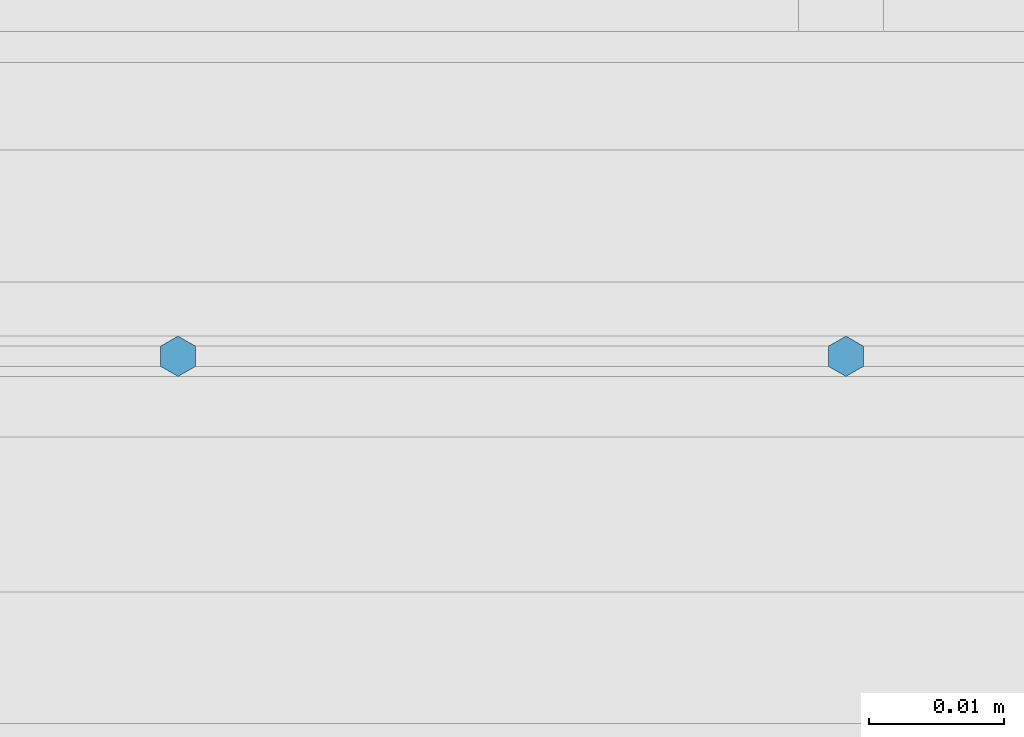
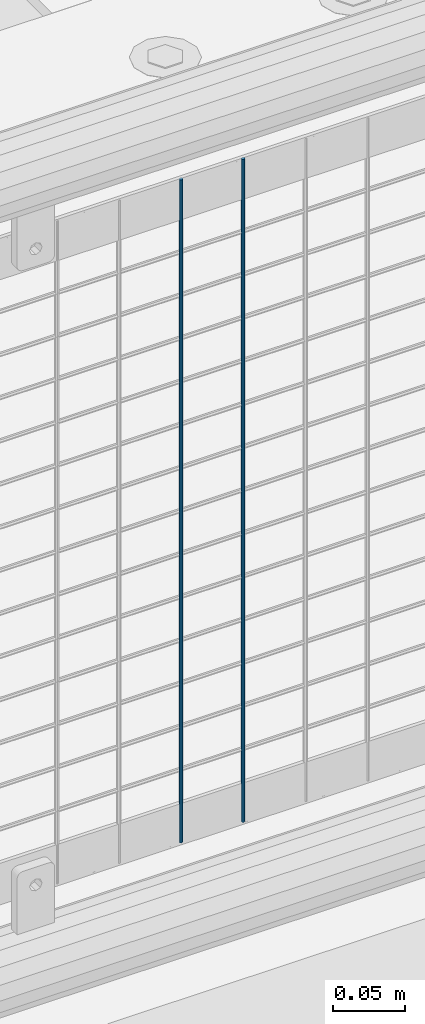
# One storey, part 84 of 208: 2 columns.
"""IFC2X3 building model written with IfcOpenShell, lengths in millimetres."""

from ifc_helpers import new_model, si_unit, frame, origin_with_axes, place, context, subcontext, project, spatial, faceted_brep, material, type_object, element, save


model = new_model("IFC2X3")

# Units and contexts
model_context = context("Model", 3, precision=1e-05, world=origin_with_axes())
body_context = subcontext(model_context, "Body", "Model", "MODEL_VIEW")
ifc_project = project(units=[si_unit("LENGTHUNIT", "METRE", prefix="MILLI"), si_unit("AREAUNIT", "SQUARE_METRE"), si_unit("VOLUMEUNIT", "CUBIC_METRE"), si_unit("MASSUNIT", "GRAM", prefix="KILO"), si_unit("TIMEUNIT", "SECOND"), si_unit("PLANEANGLEUNIT", "RADIAN"), si_unit("SOLIDANGLEUNIT", "STERADIAN"), si_unit("THERMODYNAMICTEMPERATUREUNIT", "DEGREE_CELSIUS"), si_unit("LUMINOUSINTENSITYUNIT", "LUMEN")], contexts=[model_context])

# Site, building, storey
site_placement = place(None, origin_with_axes())
site = spatial("IfcSite", under=ifc_project, at=site_placement, CompositionType="ELEMENT")
building_placement = place(site_placement, origin_with_axes())
building = spatial("IfcBuilding", under=site, at=building_placement, Name="Standard", CompositionType="ELEMENT")
storey_placement = place(building_placement, origin_with_axes())
storey = spatial("IfcBuildingStorey", under=building, at=storey_placement, Name="Undefined", CompositionType="ELEMENT", Elevation=0.0)

# Columns
ifc_material = material(Name="Misc_Undefined")
column_type = type_object("IfcColumnType", Name="D3", PredefinedType="NOTDEFINED")
for number, where, z_axis, x_axis in (
    (1, (-28402.795, 4670.50000000001, 353.020000000006), (-1.0, 0.0, 0.0), (0.0, 0.0, 1.0)),
    (2, (-28452.45, 4670.50000000001, 353.020000000006), (-1.0, 0.0, 0.0), (0.0, 0.0, 1.0)),
):
    element("IfcColumn", number, at=place(storey_placement, frame(where, z_axis=z_axis, x_axis=x_axis)), inside=storey, type_object=column_type, material=ifc_material, ObjectType="D3", context=body_context, shape_type="Brep", body=[
        faceted_brep([(0.0, -1.49999999999909, 3.63797880709171e-12), (-7.27595761418343e-12, -0.749999999999091, -1.29903810567669), (560.0, -0.75, -1.29903810567703), (560.0, -1.5, 0.0), (-3.63797880709171e-12, 0.750000000000909, -1.29903810567669), (560.0, 0.75, -1.29903810567703), (0.0, 1.50000000000182, 3.63797880709171e-12), (560.0, 1.5, 0.0), (-3.63797880709171e-12, 0.750000000000909, 1.29903810567669), (560.0, 0.75, 1.29903810567703), (-7.27595761418343e-12, -0.749999999999091, 1.29903810567669), (560.0, -0.75, 1.29903810567703)], [[[0, 1, 2, 3]], [[1, 4, 5, 2]], [[4, 6, 7, 5]], [[6, 8, 9, 7]], [[8, 10, 11, 9]], [[10, 0, 3, 11]], [[5, 7, 9, 11, 3, 2]], [[10, 8, 6, 4, 1, 0]]]),
    ])

save(model, "model.ifc")
